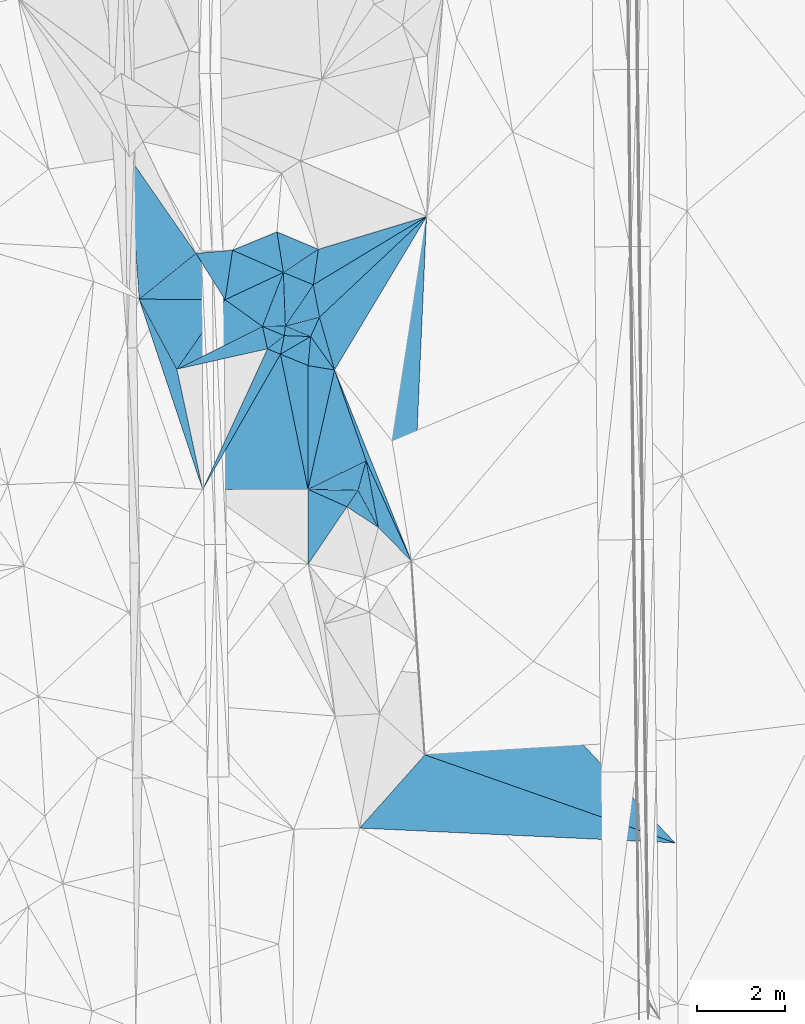
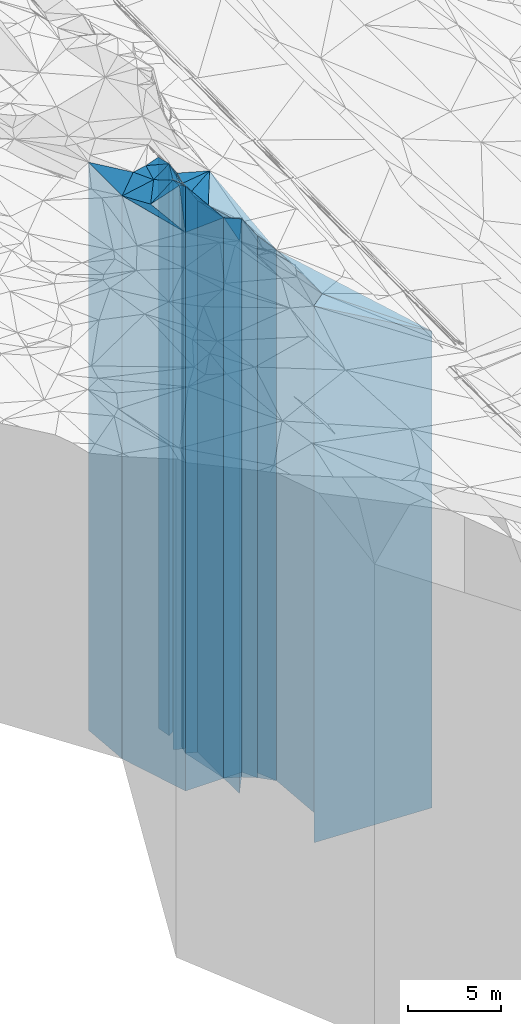
# One storey, part 197 of 275: 42 plates.
"""IFC2X3 building model written with IfcOpenShell, lengths in millimetres."""

import ifcopenshell
import ifcopenshell.guid

model = None  # the IFC model being written
_history = None  # IfcOwnerHistory: only IFC2X3 demands one
_inside = {}  # id of a spatial element -> (the spatial element, [elements in it])
_under = {}  # id of a project, library or spatial element -> (it, [spatial elements below it])
_declared = {}  # id of a project -> (the project, [libraries it declares])
_typed = {}  # id of a type object -> (the type object, [elements of that type])
_made_of = {}  # id of a material, layer set ... -> (it, [elements and type objects made of it])


def new_model(schema):
    """Start an empty IFC model of exactly this schema.

    Asked for "IFC4X3", IfcOpenShell would pick the latest addendum, in which some entities
    have other attributes; the version numbers below select the first issue.
    IFC2X3 requires an IfcOwnerHistory on every rooted entity: one is made here for all.
    """
    global model, _history
    if schema == "IFC4X3":
        model = ifcopenshell.file(schema_version=(4, 3, 0, 0))
    else:
        model = ifcopenshell.file(schema=schema)
    _inside.clear()
    _under.clear()
    _declared.clear()
    _typed.clear()
    _made_of.clear()
    _history = None
    if model.schema == "IFC2X3":
        org = make("IfcOrganization", Name="unknown")
        user = make(
            "IfcPersonAndOrganization",
            ThePerson=make("IfcPerson", FamilyName="unknown"),
            TheOrganization=org,
        )
        app = make(
            "IfcApplication",
            ApplicationDeveloper=org,
            Version="unknown",
            ApplicationFullName="unknown",
            ApplicationIdentifier="unknown",
        )
        _history = make(
            "IfcOwnerHistory",
            OwningUser=user,
            OwningApplication=app,
            ChangeAction="ADDED",
            CreationDate=0,
        )
    return model


def make(cls, **values):
    """One entity of the class cls with the attributes given. An attribute that is None is left unset."""
    return model.create_entity(
        cls, **{name: value for name, value in values.items() if value is not None}
    )


def rooted(cls, **values):
    """An entity with a GlobalId (a new one), such as an element, a storey or a relation."""
    return make(cls, GlobalId=ifcopenshell.guid.new(), OwnerHistory=_history, **values)


def si_unit(unit_type, name, prefix=None):
    """IfcSIUnit, for example si_unit("LENGTHUNIT", "METRE", prefix="MILLI")."""
    return make("IfcSIUnit", UnitType=unit_type, Prefix=prefix, Name=name)


def assignment(units):
    """IfcUnitAssignment: the units of a project."""
    return None if units is None else make("IfcUnitAssignment", Units=units)


def point(xyz):
    """IfcCartesianPoint."""
    return None if xyz is None else make("IfcCartesianPoint", Coordinates=xyz)


def direction(xyz):
    """IfcDirection."""
    return None if xyz is None else make("IfcDirection", DirectionRatios=xyz)


def frame(location, z_axis=None, x_axis=None):
    """IfcAxis2Placement3D, a coordinate frame: its origin and axes. An axis left out is left unset."""
    return make(
        "IfcAxis2Placement3D",
        Location=point(location),
        Axis=direction(z_axis),
        RefDirection=direction(x_axis),
    )


def origin_with_axes():
    """The frame at (0, 0, 0) with the z axis (0, 0, 1) and the x axis (1, 0, 0) written out."""
    return frame((0.0, 0.0, 0.0), z_axis=(0.0, 0.0, 1.0), x_axis=(1.0, 0.0, 0.0))


def place(relative_to, where):
    """IfcLocalPlacement: puts the frame where relative to a parent placement (None: the world)."""
    return make(
        "IfcLocalPlacement", PlacementRelTo=relative_to, RelativePlacement=where
    )


def context(
    kind, dimensions, precision=None, world=None, true_north=None, identifier=None
):
    """IfcGeometricRepresentationContext, for example the 3D "Model" context."""
    return make(
        "IfcGeometricRepresentationContext",
        ContextIdentifier=identifier,
        ContextType=kind,
        CoordinateSpaceDimension=dimensions,
        Precision=precision,
        WorldCoordinateSystem=world,
        TrueNorth=true_north,
    )


def subcontext(parent, identifier, kind, view, scale=None):
    """IfcGeometricRepresentationSubContext, for example "Body" below "Model"."""
    return make(
        "IfcGeometricRepresentationSubContext",
        ContextIdentifier=identifier,
        ContextType=kind,
        ParentContext=parent,
        TargetScale=scale,
        TargetView=view,
    )


def project(units=None, contexts=None):
    """IfcProject with its units and contexts."""
    return rooted(
        "IfcProject",
        Name="project",
        RepresentationContexts=contexts,
        UnitsInContext=assignment(units),
    )


def spatial(cls, under=None, at=None, **own):
    """A site, building, storey or space (cls), placed at a placement, below another one or the project."""
    s = rooted(cls, ObjectPlacement=at, **own)
    if under is not None:
        _under.setdefault(under.id(), (under, []))[1].append(s)
    return s


def faces_of(points, faces, orient=None, outer=None):
    """IfcFace entities. A face is a list of loops; a loop is a list of indices into points, from 0.

    orient and outer hold one flag for each loop. By default every Orientation is true, the
    first loop of a face is its IfcFaceOuterBound and the others are IfcFaceBound.
    """
    made = []
    for i, loops in enumerate(faces):
        bounds = []
        for j, loop in enumerate(loops):
            is_outer = j == 0 if outer is None else outer[i][j]
            bounds.append(
                make(
                    "IfcFaceOuterBound" if is_outer else "IfcFaceBound",
                    Bound=make("IfcPolyLoop", Polygon=[points[k] for k in loop]),
                    Orientation=True if orient is None else orient[i][j],
                )
            )
        made.append(make("IfcFace", Bounds=bounds))
    return made


def faceted_brep(points, faces, orient=None, outer=None, voids=None):
    """IfcFacetedBrep: a solid bounded by flat faces; with voids (closed shells), ...WithVoids."""
    shared = [point(p) for p in points]
    hull = make("IfcClosedShell", CfsFaces=faces_of(shared, faces, orient, outer))
    if voids is None:
        return make("IfcFacetedBrep", Outer=hull)
    return make(
        "IfcFacetedBrepWithVoids",
        Outer=hull,
        Voids=[
            make(cls, CfsFaces=faces_of(shared, fs, o, b)) for cls, fs, o, b in voids
        ],
    )


def shape(context_of_items, identifier, shape_type, items):
    """IfcShapeRepresentation: the items that make up one representation, for example the "Body"."""
    return make(
        "IfcShapeRepresentation",
        ContextOfItems=context_of_items,
        RepresentationIdentifier=identifier,
        RepresentationType=shape_type,
        Items=items,
    )


def material(Name=None, Category=None):
    """IfcMaterial."""
    return make("IfcMaterial", Name=Name, Category=Category)


def made_of(thing, what):
    """Note that an element or type object is made of a material, layer set ...; save() writes the relation."""
    if what is not None:
        _made_of.setdefault(what.id(), (what, []))[1].append(thing)
    return thing


def type_object(cls, material=None, **own):
    """A type object (cls), such as IfcWallType, which elements share."""
    return made_of(rooted(cls, **own), material)


def element(
    cls,
    number,
    at=None,
    inside=None,
    cuts=None,
    type_object=None,
    material=None,
    context=None,
    identifier="Body",
    shape_type=None,
    held_by="IfcProductDefinitionShape",
    body=None,
    shapes=None,
    **own,
):
    """One element of the class cls, such as IfcWall. Its Tag is "e" and its number.

    at: its placement. inside: the storey or other place that contains it. cuts: it is an
    opening in that element (IfcRelVoidsElement). A single representation is given by context,
    identifier, shape_type and body (its items); several are given by shapes. held_by: the class
    of the entity that holds the representations. save() writes the other relations.
    """
    e = rooted(cls, Tag="e%d" % number, ObjectPlacement=at, **own)
    if body is not None:
        shapes = [shape(context, identifier, shape_type, body)]
    if shapes is not None:
        e.Representation = make(held_by, Representations=shapes)
    if inside is not None:
        _inside.setdefault(inside.id(), (inside, []))[1].append(e)
    if cuts is not None:
        rooted(
            "IfcRelVoidsElement", RelatingBuildingElement=cuts, RelatedOpeningElement=e
        )
    if type_object is not None:
        _typed.setdefault(type_object.id(), (type_object, []))[1].append(e)
    return made_of(e, material)


def aggregate(whole, parts):
    """IfcRelAggregates: a whole, such as a stair, and the parts it consists of."""
    return rooted("IfcRelAggregates", RelatingObject=whole, RelatedObjects=parts)


def save(model, path):
    """Write the relations noted so far, then the file.

    IfcRelAggregates (storeys below a building ...), IfcRelContainedInSpatialStructure (elements
    in a storey), IfcRelDefinesByType, IfcRelAssociatesMaterial and IfcRelDeclares: one each for
    every whole, place, type object, material and project.
    """
    for whole, parts in _under.values():
        aggregate(whole, parts)
    for where, things in _inside.values():
        rooted(
            "IfcRelContainedInSpatialStructure",
            RelatedElements=things,
            RelatingStructure=where,
        )
    for kind, things in _typed.values():
        rooted("IfcRelDefinesByType", RelatedObjects=things, RelatingType=kind)
    for what, things in _made_of.values():
        rooted("IfcRelAssociatesMaterial", RelatedObjects=things, RelatingMaterial=what)
    for by, libraries in _declared.values():
        rooted("IfcRelDeclares", RelatingContext=by, RelatedDefinitions=libraries)
    model.write(path)


model = new_model("IFC2X3")

# Units and contexts
model_context = context("Model", 3, precision=1e-05, world=origin_with_axes())
body_context = subcontext(model_context, "Body", "Model", "MODEL_VIEW")
ifc_project = project(units=[si_unit("LENGTHUNIT", "METRE", prefix="MILLI"), si_unit("AREAUNIT", "SQUARE_METRE"), si_unit("VOLUMEUNIT", "CUBIC_METRE"), si_unit("MASSUNIT", "GRAM", prefix="KILO"), si_unit("TIMEUNIT", "SECOND"), si_unit("PLANEANGLEUNIT", "RADIAN"), si_unit("SOLIDANGLEUNIT", "STERADIAN"), si_unit("THERMODYNAMICTEMPERATUREUNIT", "DEGREE_CELSIUS"), si_unit("LUMINOUSINTENSITYUNIT", "LUMEN")], contexts=[model_context])

# Site, building, storey
site_placement = place(None, origin_with_axes())
site = spatial("IfcSite", under=ifc_project, at=site_placement, CompositionType="ELEMENT")
building_placement = place(site_placement, origin_with_axes())
building = spatial("IfcBuilding", under=site, at=building_placement, Name="Undefined", CompositionType="ELEMENT")
storey_placement = place(building_placement, origin_with_axes())
storey = spatial("IfcBuildingStorey", under=building, at=storey_placement, Name="Undefined", CompositionType="ELEMENT", Elevation=0.0)

# Plates
ifc_material = material()
plate_type_1 = type_object("IfcPlateType", PredefinedType="NOTDEFINED")
plate_1_placement = place(storey_placement, frame((-98977.5774845146, 11704.5980835272, 23535.0), z_axis=(0.997621794008999, 0.0689257290006218, 0.0), x_axis=(0.0689257290006226, -0.997621794008999, 0.0)))
element("IfcPlate", 1, at=plate_1_placement, inside=storey, type_object=plate_type_1, material=ifc_material, Name="00", context=body_context, shape_type="Brep", body=[
    faceted_brep([(0.0, -19252.4609375, 0.0), (6798.1015625, -15707.0, 5531.57373046875), (6798.1015625, 15707.0, 5531.57373046875), (0.0, 15707.0, 0.0), (4412.50537109375, -18941.4609375, 3.08500602841377e-09), (4412.50537109375, 15707.0, 3.08500602841377e-09)], [[[0, 1, 2, 3]], [[1, 4, 5, 2]], [[4, 0, 3, 5]], [[5, 3, 2]], [[4, 1, 0]]]),
])
plate_type_2 = type_object("IfcPlateType", PredefinedType="NOTDEFINED")
plate_2_placement = place(storey_placement, frame((-102030.296716859, 19177.3864713029, 26639.0), z_axis=(0.37908068696638, -0.925363621917945, 0.0), x_axis=(-0.925363621917943, -0.379080686966386, 0.0)))
element("IfcPlate", 2, at=plate_2_placement, inside=storey, type_object=plate_type_2, material=ifc_material, Name="00", context=body_context, shape_type="Brep", body=[
    faceted_brep([(0.0, -18811.0, 0.0), (215.147888183594, -18881.0, 906.262329101548), (215.147888183594, 18811.0, 906.262329101548), (0.0, 18811.0, 0.0), (1090.41271972656, -18861.0, -5.0931703299284e-10), (1090.41271972656, 18811.0, -5.0931703299284e-10)], [[[0, 1, 2, 3]], [[1, 4, 5, 2]], [[4, 0, 3, 5]], [[5, 3, 2]], [[4, 1, 0]]]),
])
plate_type_3 = type_object("IfcPlateType", PredefinedType="NOTDEFINED")
plate_3_placement = place(storey_placement, frame((-101205.072402421, 17978.7185311039, 25489.0), z_axis=(-0.516023395156627, 0.856574489259998, 0.0), x_axis=(0.856574489259998, 0.516023395156628, 0.0)))
element("IfcPlate", 3, at=plate_3_placement, inside=storey, type_object=plate_type_3, material=ifc_material, Name="00", context=body_context, shape_type="Brep", body=[
    faceted_brep([(0.0, -18681.0, 0.0), (513.227783203125, -18821.0, 630.553161621094), (513.227783203125, 17661.0, 630.553161621094), (-2.91038304567337e-11, 17661.0, 1.45519152283669e-11), (3002.76049804688, -17661.0, 1.71858118847013e-08), (3002.76049804688, 17661.0, 1.71858118847013e-08)], [[[0, 1, 2, 3]], [[1, 4, 5, 2]], [[4, 0, 3, 5]], [[5, 3, 2]], [[4, 1, 0]]]),
])
plate_type_4 = type_object("IfcPlateType", PredefinedType="NOTDEFINED")
plate_4_placement = place(storey_placement, frame((-101090.834766413, 18783.6717983929, 25999.0), z_axis=(0.552128983358343, -0.833758709541125, 0.0), x_axis=(-0.833758709541124, -0.552128983358345, 0.0)))
element("IfcPlate", 4, at=plate_4_placement, inside=storey, type_object=plate_type_4, material=ifc_material, Name="00", context=body_context, shape_type="Brep", body=[
    faceted_brep([(-1.45519152283669e-11, -18311.0, 1.45519152283669e-11), (539.684631347642, -18171.0, 608.062866210952), (539.684631347642, 18171.0, 608.062866210952), (-1.45519152283669e-11, 18171.0, 1.45519152283669e-11), (953.51977539061, -19521.0, -6.98491930961609e-10), (953.51977539061, 18171.0, -6.98491930961609e-10)], [[[0, 1, 2, 3]], [[1, 4, 5, 2]], [[4, 0, 3, 5]], [[5, 3, 2]], [[4, 1, 0]]]),
])
plate_type_5 = type_object("IfcPlateType", PredefinedType="NOTDEFINED")
plate_5_placement = place(storey_placement, frame((-101840.435153924, 17041.7477876956, 25939.0), z_axis=(-0.250525793019812, 0.968109925076587, 0.0), x_axis=(0.968109925076585, 0.250525793019819, 0.0)))
element("IfcPlate", 5, at=plate_5_placement, inside=storey, type_object=plate_type_5, material=ifc_material, Name="00", context=body_context, shape_type="Brep", body=[
    faceted_brep([(-1.45519152283669e-11, -18941.0, 0.0), (849.836303710923, -18231.0, 747.915893554688), (849.836303710923, 18111.0, 747.915893554688), (-1.45519152283669e-11, 18111.0, 0.0), (800.624755859375, -18111.0, 4.35829861089587e-09), (800.624755859375, 18111.0, 4.35829861089587e-09)], [[[0, 1, 2, 3]], [[1, 4, 5, 2]], [[4, 0, 3, 5]], [[5, 3, 2]], [[4, 1, 0]]]),
])
plate_type_6 = type_object("IfcPlateType", PredefinedType="NOTDEFINED")
plate_6_placement = place(storey_placement, frame((-101885.840200398, 18257.205883129, 26069.0), z_axis=(-0.552128983358343, 0.833758709541125, 0.0), x_axis=(0.833758709541123, 0.552128983358347, 0.0)))
element("IfcPlate", 6, at=plate_6_placement, inside=storey, type_object=plate_type_6, material=ifc_material, Name="00", context=body_context, shape_type="Brep", body=[
    faceted_brep([(0.0, -19451.0, 0.0), (387.616485595689, -19381.0, 846.967224121094), (387.616485595689, 18241.0, 846.967224121094), (0.0, 18241.0, 0.0), (953.519775390625, -18241.0, -6.98491930961609e-10), (953.519775390625, 18241.0, -6.98491930961609e-10)], [[[0, 1, 2, 3]], [[1, 4, 5, 2]], [[4, 0, 3, 5]], [[5, 3, 2]], [[4, 1, 0]]]),
])
plate_type_7 = type_object("IfcPlateType", PredefinedType="NOTDEFINED")
plate_7_placement = place(storey_placement, frame((-101205.072402421, 17978.7185311039, 25999.0), z_axis=(-0.378622870041879, -0.925551037102358, 0.0), x_axis=(-0.925551037102361, 0.378622870041871, 0.0)))
element("IfcPlate", 7, at=plate_7_placement, inside=storey, type_object=plate_type_7, material=ifc_material, Name="00", context=body_context, shape_type="Brep", body=[
    faceted_brep([(-1.45519152283669e-11, -18171.0, 7.27595761418343e-12), (233.302108764634, -18881.0, 1107.77709960938), (233.302108764634, 18171.0, 1107.77709960938), (-1.45519152283669e-11, 18171.0, 1.45519152283669e-11), (735.527038574204, -19521.0, -3.1177478376776e-09), (735.527038574204, 18171.0, -3.1177478376776e-09)], [[[0, 1, 2, 3]], [[1, 4, 5, 2]], [[4, 0, 3, 5]], [[5, 3, 2]], [[4, 1, 0]]]),
])
plate_type_8 = type_object("IfcPlateType", PredefinedType="NOTDEFINED")
plate_8_placement = place(storey_placement, frame((-102360.3146659, 17030.5543508726, 26354.0), z_axis=(-0.0215258400056386, 0.999768292261788, 0.0), x_axis=(0.999768292261788, 0.0215258400056351, 0.0)))
element("IfcPlate", 8, at=plate_8_placement, inside=storey, type_object=plate_type_8, material=ifc_material, Name="00", context=body_context, shape_type="Brep", body=[
    faceted_brep([(-1.45519152283669e-11, -19006.0, 3.63797880709171e-12), (500.769226074204, -19166.0, 1216.15380859375), (500.769226074204, 18526.0, 1216.15380859375), (-1.45519152283669e-11, 18526.0, 3.63797880709171e-12), (519.999999999985, -18526.0, 3.04135028272867e-09), (519.999999999985, 18526.0, 3.04135028272867e-09)], [[[0, 1, 2, 3]], [[1, 4, 5, 2]], [[4, 0, 3, 5]], [[5, 3, 2]], [[4, 1, 0]]]),
])
plate_type_9 = type_object("IfcPlateType", PredefinedType="NOTDEFINED")
plate_9_placement = place(storey_placement, frame((-101205.072402421, 17978.7185311039, 25489.0), z_axis=(0.982469626415243, 0.186422727078792, 0.0), x_axis=(0.186422727078798, -0.982469626415241, 0.0)))
element("IfcPlate", 9, at=plate_9_placement, inside=storey, type_object=plate_type_9, material=ifc_material, Name="00", context=body_context, shape_type="Brep", body=[
    faceted_brep([(0.0, -18681.0, 0.0), (-1042.8356933594, -17661.0, 2815.859375), (-1042.8356933594, 17661.0, 2815.859375), (-2.91038304567337e-11, 17661.0, 1.45519152283669e-11), (749.533203124993, -18561.0, 1.25146470963955e-09), (749.533203124993, 17661.0, 1.25146470963955e-09)], [[[0, 1, 2, 3]], [[1, 4, 5, 2]], [[4, 0, 3, 5]], [[5, 3, 2]], [[4, 1, 0]]]),
])
plate_type_10 = type_object("IfcPlateType", PredefinedType="NOTDEFINED")
plate_10_placement = place(storey_placement, frame((-103209.000762078, 17639.3498092609, 26569.0), z_axis=(0.582879703926358, 0.812558459897331, 0.0), x_axis=(0.812558459897334, -0.582879703926353, 0.0)))
element("IfcPlate", 10, at=plate_10_placement, inside=storey, type_object=plate_type_10, material=ifc_material, Name="00", context=body_context, shape_type="Brep", body=[
    faceted_brep([(0.0, -18741.0, -1.45519152283669e-11), (715.009521484375, -18951.0, 1273.28759765624), (715.009521484375, 18741.0, 1273.28759765624), (0.0, 18741.0, -1.45519152283669e-11), (1044.46154785156, -18791.0, -5.81349013373256e-09), (1044.46154785156, 18741.0, -5.81349013373256e-09)], [[[0, 1, 2, 3]], [[1, 4, 5, 2]], [[4, 0, 3, 5]], [[5, 3, 2]], [[4, 1, 0]]]),
])
plate_type_11 = type_object("IfcPlateType", PredefinedType="NOTDEFINED")
plate_11_placement = place(storey_placement, frame((-101065.342381393, 17242.3249398611, 25939.0), z_axis=(0.250525793019812, -0.968109925076587, 0.0), x_axis=(-0.968109925076585, -0.250525793019819, 0.0)))
element("IfcPlate", 11, at=plate_11_placement, inside=storey, type_object=plate_type_11, material=ifc_material, Name="00", context=body_context, shape_type="Brep", body=[
    faceted_brep([(0.0, -18111.0, 0.0), (303.263153076157, -18181.0, 374.207763671875), (303.263153076157, 18111.0, 374.207763671875), (-1.45519152283669e-11, 18111.0, 0.0), (800.624755859375, -18941.0, 4.36557456851006e-09), (800.624755859375, 18111.0, 4.35829861089587e-09)], [[[0, 1, 2, 3]], [[1, 4, 5, 2]], [[4, 0, 3, 5]], [[5, 3, 2]], [[4, 1, 0]]]),
])
plate_type_12 = type_object("IfcPlateType", PredefinedType="NOTDEFINED")
plate_12_placement = place(storey_placement, frame((-104304.522036039, 16061.5560526824, 26434.0), z_axis=(-0.446069600734748, 0.894998274467802, 0.0), x_axis=(0.894998274467801, 0.44606960073475, 0.0)))
element("IfcPlate", 12, at=plate_12_placement, inside=storey, type_object=plate_type_12, material=ifc_material, Name="00", context=body_context, shape_type="Brep", body=[
    faceted_brep([(1.45519152283669e-11, -18606.0, -7.27595761418343e-12), (1684.29553222656, -18876.0, 923.443969726555), (1684.29553222656, 18606.0, 923.443969726555), (1.45519152283669e-11, 18606.0, -7.27595761418343e-12), (2172.30297851563, -18926.0, 7.49423634260893e-09), (2172.30297851563, 18606.0, 7.49423634260893e-09)], [[[0, 1, 2, 3]], [[1, 4, 5, 2]], [[4, 0, 3, 5]], [[5, 3, 2]], [[4, 1, 0]]]),
])
plate_type_13 = type_object("IfcPlateType", PredefinedType="NOTDEFINED")
plate_13_placement = place(storey_placement, frame((-105161.285860759, 17653.0207078513, 26372.5), z_axis=(0.00700234000222417, 0.999975483316713, 0.0), x_axis=(0.999975483316713, -0.00700234000221785, 0.0)))
element("IfcPlate", 13, at=plate_13_placement, inside=storey, type_object=plate_type_13, material=ifc_material, Name="00", context=body_context, shape_type="Brep", body=[
    faceted_brep([(-1.45519152283669e-11, -18544.5, 0.0), (1282.94921874999, -19027.5, 1047.48522949219), (1282.94921874999, 18544.5, 1047.48522949219), (-1.45519152283669e-11, 18544.5, 0.0), (1952.33300781247, -18937.5, -1.17688614409417e-08), (1952.33300781247, 18544.5, -1.17688614409417e-08)], [[[0, 1, 2, 3]], [[1, 4, 5, 2]], [[4, 0, 3, 5]], [[5, 3, 2]], [[4, 1, 0]]]),
])
plate_type_14 = type_object("IfcPlateType", PredefinedType="NOTDEFINED")
plate_14_placement = place(storey_placement, frame((-101864.204087832, 16823.4932624714, 25974.0), z_axis=(0.0323990509981042, 0.999475012941505, 0.0), x_axis=(0.999475012941505, -0.0323990509981041, 0.0)))
element("IfcPlate", 14, at=plate_14_placement, inside=storey, type_object=plate_type_14, material=ifc_material, Name="00", context=body_context, shape_type="Brep", body=[
    faceted_brep([(-1.45519152283669e-11, -19066.0, 0.0), (16.685216903672, -18906.0, 218.910034179686), (16.685216903672, 18146.0, 218.910034179686), (-1.45519152283669e-11, 18146.0, 0.0), (599.332946777329, -18146.0, -7.1122485678643e-10), (599.332946777329, 18146.0, -7.1122485678643e-10)], [[[0, 1, 2, 3]], [[1, 4, 5, 2]], [[4, 0, 3, 5]], [[5, 3, 2]], [[4, 1, 0]]]),
])
plate_type_15 = type_object("IfcPlateType", PredefinedType="NOTDEFINED")
plate_15_placement = place(storey_placement, frame((-100722.817014246, 16042.3431179736, 25489.0), z_axis=(-0.857676258769499, 0.514190076861811, 0.0), x_axis=(0.51419007686181, 0.8576762587695, 0.0)))
element("IfcPlate", 15, at=plate_15_placement, inside=storey, type_object=plate_type_15, material=ifc_material, Name="00", context=body_context, shape_type="Brep", body=[
    faceted_brep([(0.0, -18213.0, 0.0), (853.07275390625, -18561.0, 910.794616699219), (853.07275390625, 17661.0, 910.794616699219), (-2.91038304567337e-11, 17661.0, 1.45519152283669e-11), (4064.31909179688, -17661.0, -1.13795977085829e-08), (4064.31909179688, 17661.0, -1.13795977085829e-08)], [[[0, 1, 2, 3]], [[1, 4, 5, 2]], [[4, 0, 3, 5]], [[5, 3, 2]], [[4, 1, 0]]]),
])
plate_type_16 = type_object("IfcPlateType", PredefinedType="NOTDEFINED")
plate_16_placement = place(storey_placement, frame((-101840.435153924, 17041.7477876956, 26354.0), z_axis=(0.0215258400056386, -0.999768292261788, 0.0), x_axis=(-0.999768292261788, -0.0215258400056351, 0.0)))
element("IfcPlate", 16, at=plate_16_placement, inside=storey, type_object=plate_type_16, material=ifc_material, Name="00", context=body_context, shape_type="Brep", body=[
    faceted_brep([(1.45519152283669e-11, -18526.0, 0.0), (28.4615383148193, -18686.0, 217.692306518555), (28.4615383148193, 18526.0, 217.692306518555), (-1.45519152283669e-11, 18526.0, 3.63797880709171e-12), (520.000000000015, -19006.0, 3.03771230392158e-09), (519.999999999985, 18526.0, 3.04135028272867e-09)], [[[0, 1, 2, 3]], [[1, 4, 5, 2]], [[4, 0, 3, 5]], [[5, 3, 2]], [[4, 1, 0]]]),
])
plate_type_17 = type_object("IfcPlateType", PredefinedType="NOTDEFINED")
plate_17_placement = place(storey_placement, frame((-101323.302767628, 16144.2099918098, 25765.0), z_axis=(0.167251275010265, 0.985914302060499, 0.0), x_axis=(0.985914302060499, -0.167251275010262, 0.0)))
element("IfcPlate", 17, at=plate_17_placement, inside=storey, type_object=plate_type_17, material=ifc_material, Name="00", context=body_context, shape_type="Brep", body=[
    faceted_brep([(0.0, -18405.0, 2.72848410531878e-12), (-53.0649566650391, -18355.0, 660.290954589845), (-53.0649566650391, 17937.0, 660.290954589845), (0.0, 17937.0, 2.72848410531878e-12), (609.064880371079, -17937.0, 3.96994437323883e-09), (609.064880371079, 17937.0, 3.96994437323883e-09)], [[[0, 1, 2, 3]], [[1, 4, 5, 2]], [[4, 0, 3, 5]], [[5, 3, 2]], [[4, 1, 0]]]),
])
plate_type_18 = type_object("IfcPlateType", PredefinedType="NOTDEFINED")
plate_18_placement = place(storey_placement, frame((-101951.311359916, 16402.2898399424, 25974.0), z_axis=(0.380105042995066, 0.924943325987987, 0.0), x_axis=(0.924943325987988, -0.380105042995063, 0.0)))
element("IfcPlate", 18, at=plate_18_placement, inside=storey, type_object=plate_type_18, material=ifc_material, Name="00", context=body_context, shape_type="Brep", body=[
    faceted_brep([(-1.45519152283669e-11, -19236.0, 0.0), (481.906555175767, -18146.0, 632.428710937493), (481.906555175767, 18146.0, 632.428710937493), (-1.45519152283669e-11, 18146.0, 0.0), (678.969787597642, -18196.0, -8.00355337560177e-10), (678.969787597642, 18146.0, -8.00355337560177e-10)], [[[0, 1, 2, 3]], [[1, 4, 5, 2]], [[4, 0, 3, 5]], [[5, 3, 2]], [[4, 1, 0]]]),
])
plate_type_19 = type_object("IfcPlateType", PredefinedType="NOTDEFINED")
plate_19_placement = place(storey_placement, frame((-101065.342381393, 17242.3249398611, 25765.0), z_axis=(0.909865993098482, -0.414902247044907, 0.0), x_axis=(-0.414902247044917, -0.909865993098478, 0.0)))
element("IfcPlate", 19, at=plate_19_placement, inside=storey, type_object=plate_type_19, material=ifc_material, Name="00", context=body_context, shape_type="Brep", body=[
    faceted_brep([(7.27595761418343e-12, -18285.0, -1.45519152283669e-11), (949.708129882827, -17937.0, 809.52734375), (949.708129882827, 17937.0, 809.52734375), (0.0, 17937.0, 2.72848410531878e-12), (481.663787841801, -18355.0, -1.58615875989199e-09), (481.663787841801, 17937.0, -1.58615875989199e-09)], [[[0, 1, 2, 3]], [[1, 4, 5, 2]], [[4, 0, 3, 5]], [[5, 3, 2]], [[4, 1, 0]]]),
])
plate_type_20 = type_object("IfcPlateType", PredefinedType="NOTDEFINED")
plate_20_placement = place(storey_placement, frame((-101885.840200398, 18257.205883129, 26569.0), z_axis=(-0.402268328914255, -0.915521813804856, 0.0), x_axis=(-0.915521813804854, 0.402268328914258, 0.0)))
element("IfcPlate", 20, at=plate_20_placement, inside=storey, type_object=plate_type_20, material=ifc_material, Name="00", context=body_context, shape_type="Brep", body=[
    faceted_brep([(1.45519152283669e-11, -18951.0, 3.63797880709171e-12), (962.838439941421, -18741.0, 1097.92626953125), (962.838439941421, 18741.0, 1097.92626953125), (0.0, 18741.0, -1.45519152283669e-11), (1259.92065429688, -18931.0, -1.11685949377716e-09), (1259.92065429688, 18741.0, -1.11685949377716e-09)], [[[0, 1, 2, 3]], [[1, 4, 5, 2]], [[4, 0, 3, 5]], [[5, 3, 2]], [[4, 1, 0]]]),
])
plate_type_21 = type_object("IfcPlateType", PredefinedType="NOTDEFINED")
plate_21_placement = place(storey_placement, frame((-103039.325023073, 18764.0320504265, 26569.0), z_axis=(0.0868827749992972, -0.996218541991877, 0.0), x_axis=(-0.996218541991878, -0.0868827749992902, 0.0)))
element("IfcPlate", 21, at=plate_21_placement, inside=storey, type_object=plate_type_21, material=ifc_material, Name="00", context=body_context, shape_type="Brep", body=[
    faceted_brep([(0.0, -18931.0, 0.0), (266.749633789077, -18741.0, 1105.68737792969), (266.749633789077, 18741.0, 1105.68737792969), (0.0, 18741.0, -1.45519152283669e-11), (834.865234375015, -18831.0, -5.50789991393685e-09), (834.865234375015, 18741.0, -5.50789991393685e-09)], [[[0, 1, 2, 3]], [[1, 4, 5, 2]], [[4, 0, 3, 5]], [[5, 3, 2]], [[4, 1, 0]]]),
])
plate_type_22 = type_object("IfcPlateType", PredefinedType="NOTDEFINED")
plate_22_placement = place(storey_placement, frame((-103717.683263969, 13327.3239382497, 26228.0), z_axis=(-0.867117462759237, 0.498103709861695, 0.0), x_axis=(0.498103709861696, 0.867117462759236, 0.0)))
element("IfcPlate", 22, at=plate_22_placement, inside=storey, type_object=plate_type_22, material=ifc_material, Name="00", context=body_context, shape_type="Brep", body=[
    faceted_brep([(0.0, -18400.0, 0.0), (3504.89794921874, -19042.0, 315.586303710938), (3504.89794921874, 18400.0, 315.586303710938), (0.0, 18400.0, 0.0), (3546.19311523438, -18982.0, 8.87666828930378e-09), (3546.19311523438, 18400.0, 8.87666828930378e-09)], [[[0, 1, 2, 3]], [[1, 4, 5, 2]], [[4, 0, 3, 5]], [[5, 3, 2]], [[4, 1, 0]]]),
])
plate_type_23 = type_object("IfcPlateType", PredefinedType="NOTDEFINED")
plate_23_placement = place(storey_placement, frame((-104304.522036039, 16061.5560526824, 26434.0), z_axis=(-0.218992509967534, 0.975726539855363, 0.0), x_axis=(0.975726539855362, 0.218992509967537, 0.0)))
element("IfcPlate", 23, at=plate_23_placement, inside=storey, type_object=plate_type_23, material=ifc_material, Name="00", context=body_context, shape_type="Brep", body=[
    faceted_brep([(1.45519152283669e-11, -18606.0, -7.27595761418343e-12), (2109.21801757811, -18926.0, 519.710510253906), (2109.21801757811, 18606.0, 519.710510253906), (1.45519152283669e-11, 18606.0, -7.27595761418343e-12), (2110.21337890624, -18836.0, 1.43409124575555e-08), (2110.21337890624, 18606.0, 1.43409124575555e-08)], [[[0, 1, 2, 3]], [[1, 4, 5, 2]], [[4, 0, 3, 5]], [[5, 3, 2]], [[4, 1, 0]]]),
])
plate_type_24 = type_object("IfcPlateType", PredefinedType="NOTDEFINED")
plate_24_placement = place(storey_placement, frame((-101864.204087832, 16823.4932624714, 26434.0), z_axis=(-0.385167443836916, -0.922846704609241, 0.0), x_axis=(-0.922846704609243, 0.385167443836912, 0.0)))
element("IfcPlate", 24, at=plate_24_placement, inside=storey, type_object=plate_type_24, material=ifc_material, Name="00", context=body_context, shape_type="Brep", body=[
    faceted_brep([(1.45519152283669e-11, -18606.0, -7.27595761418343e-12), (236.4267578125, -18836.0, 423.559204101566), (236.4267578125, 18606.0, 423.559204101566), (1.45519152283669e-11, 18606.0, -7.27595761418343e-12), (537.587219238281, -18926.0, -3.31419869326055e-09), (537.587219238281, 18606.0, -3.31419869326055e-09)], [[[0, 1, 2, 3]], [[1, 4, 5, 2]], [[4, 0, 3, 5]], [[5, 3, 2]], [[4, 1, 0]]]),
])
plate_type_25 = type_object("IfcPlateType", PredefinedType="NOTDEFINED")
plate_25_placement = place(storey_placement, frame((-103871.033273747, 18691.4966400278, 26372.5), z_axis=(-0.821652914022531, -0.569988148015626, 0.0), x_axis=(-0.569988148015627, 0.82165291402253, 0.0)))
element("IfcPlate", 25, at=plate_25_placement, inside=storey, type_object=plate_type_25, material=ifc_material, Name="00", context=body_context, shape_type="Brep", body=[
    faceted_brep([(0.0, -19027.5, 0.0), (-117.838096618652, -18544.5, 1652.05871582031), (-117.838096618652, 18544.5, 1652.05871582031), (-1.45519152283669e-11, 18544.5, 0.0), (2660.97314453125, -18889.5, -5.3987605497241e-09), (2660.97314453125, 18544.5, -5.3987605497241e-09)], [[[0, 1, 2, 3]], [[1, 4, 5, 2]], [[4, 0, 3, 5]], [[5, 3, 2]], [[4, 1, 0]]]),
])
plate_type_26 = type_object("IfcPlateType", PredefinedType="NOTDEFINED")
plate_26_placement = place(storey_placement, frame((-103209.000762078, 17639.3498092609, 26372.5), z_axis=(-0.00700234000222417, -0.999975483316713, 0.0), x_axis=(-0.999975483316713, 0.0070023400022179, 0.0)))
element("IfcPlate", 26, at=plate_26_placement, inside=storey, type_object=plate_type_26, material=ifc_material, Name="00", context=body_context, shape_type="Brep", body=[
    faceted_brep([(1.45519152283669e-11, -18937.5, 3.63797880709171e-12), (1084.44616699219, -18667.5, 1585.42626953125), (1084.44616699219, 18544.5, 1585.42626953125), (-1.45519152283669e-11, 18544.5, 0.0), (1952.33300781251, -18544.5, -1.17652234621346e-08), (1952.33300781247, 18544.5, -1.17688614409417e-08)], [[[0, 1, 2, 3]], [[1, 4, 5, 2]], [[4, 0, 3, 5]], [[5, 3, 2]], [[4, 1, 0]]]),
])
plate_type_27 = type_object("IfcPlateType", PredefinedType="NOTDEFINED")
plate_27_placement = place(storey_placement, frame((-101326.629958963, 13332.7176959288, 25765.0), z_axis=(-0.976059198429088, 0.217505037095618, 0.0), x_axis=(0.217505037095619, 0.976059198429088, 0.0)))
element("IfcPlate", 27, at=plate_27_placement, inside=storey, type_object=plate_type_27, material=ifc_material, Name="00", context=body_context, shape_type="Brep", body=[
    faceted_brep([(-1.81898940354586e-12, -18995.0, 2.91038304567337e-11), (2744.90649414062, -18405.0, 608.266174316435), (2744.90649414062, 17937.0, 608.266174316435), (0.0, 17937.0, 2.72848410531878e-12), (2776.08715820312, -17937.0, -3.11410985887051e-09), (2776.08715820312, 17937.0, -3.11410985887051e-09)], [[[0, 1, 2, 3]], [[1, 4, 5, 2]], [[4, 0, 3, 5]], [[5, 3, 2]], [[4, 1, 0]]]),
])
plate_type_28 = type_object("IfcPlateType", PredefinedType="NOTDEFINED")
plate_28_placement = place(storey_placement, frame((-101326.629958963, 13332.7176959288, 25999.0), z_axis=(-0.99999929975239, 0.00118342499970624, 0.0), x_axis=(0.00118342499970787, 0.99999929975239, 0.0)))
element("IfcPlate", 28, at=plate_28_placement, inside=storey, type_object=plate_type_28, material=ifc_material, Name="00", context=body_context, shape_type="Brep", body=[
    faceted_brep([(0.0, -18761.0, 0.0), (3068.83081054688, -19211.0, 628.313598632813), (3068.83081054688, 18171.0, 628.313598632813), (-1.45519152283669e-11, 18171.0, 1.45519152283669e-11), (2811.49438476563, -18171.0, 1.13504938781261e-09), (2811.49438476563, 18171.0, 1.13504938781261e-09)], [[[0, 1, 2, 3]], [[1, 4, 5, 2]], [[4, 0, 3, 5]], [[5, 3, 2]], [[4, 1, 0]]]),
])
plate_type_29 = type_object("IfcPlateType", PredefinedType="NOTDEFINED")
plate_29_placement = place(storey_placement, frame((-104304.522036039, 16061.5560526824, 26228.0), z_axis=(-0.880512363898619, -0.474023181945425, 0.0), x_axis=(-0.474023181945422, 0.880512363898621, 0.0)))
element("IfcPlate", 29, at=plate_29_placement, inside=storey, type_object=plate_type_29, material=ifc_material, Name="00", context=body_context, shape_type="Brep", body=[
    faceted_brep([(0.0, -18812.0, 0.0), (-2685.70043945313, -18400.0, 779.37060546875), (-2685.70043945313, 18400.0, 779.37060546875), (0.0, 18400.0, 0.0), (1807.43017578125, -18689.0, -2.57568899542093e-09), (1807.43017578125, 18400.0, -2.57568899542093e-09)], [[[0, 1, 2, 3]], [[1, 4, 5, 2]], [[4, 0, 3, 5]], [[5, 3, 2]], [[4, 1, 0]]]),
])
plate_type_30 = type_object("IfcPlateType", PredefinedType="NOTDEFINED")
plate_30_placement = place(storey_placement, frame((-99729.1112312007, 12464.5967858893, 25307.5), z_axis=(0.711055604032508, 0.703135782032151, 0.0), x_axis=(0.703135782032151, -0.711055604032508, 0.0)))
element("IfcPlate", 30, at=plate_30_placement, inside=storey, type_object=plate_type_30, material=ifc_material, Name="00", context=body_context, shape_type="Brep", body=[
    faceted_brep([(0.0, -18222.5, -7.27595761418343e-12), (-1274.00793457031, -18312.5, 869.772155761726), (-1274.00793457031, 17479.5, 869.772155761726), (0.0, 17479.5, -7.27595761418343e-12), (1068.83166503906, -17479.5, 2.47382558882236e-10), (1068.83166503906, 17479.5, 2.47382558882236e-10)], [[[0, 1, 2, 3]], [[1, 4, 5, 2]], [[4, 0, 3, 5]], [[5, 3, 2]], [[4, 1, 0]]]),
])
plate_type_31 = type_object("IfcPlateType", PredefinedType="NOTDEFINED")
plate_31_placement = place(storey_placement, frame((-100006.45544676, 13982.0552486144, 25307.5), z_axis=(0.911318220107726, 0.411702686048667, 0.0), x_axis=(0.411702686048667, -0.911318220107726, 0.0)))
element("IfcPlate", 31, at=plate_31_placement, inside=storey, type_object=plate_type_31, material=ifc_material, Name="00", context=body_context, shape_type="Brep", body=[
    faceted_brep([(-1.45519152283669e-11, -18312.5, -1.45519152283669e-11), (-2172.50585937501, -18394.5, 195.392700195298), (-2172.50585937501, 17479.5, 195.392700195298), (0.0, 17479.5, -7.27595761418343e-12), (2499.08007812499, -17479.5, 3.92901711165905e-10), (2499.08007812499, 17479.5, 3.92901711165905e-10)], [[[0, 1, 2, 3]], [[1, 4, 5, 2]], [[4, 0, 3, 5]], [[5, 3, 2]], [[4, 1, 0]]]),
])
plate_type_32 = type_object("IfcPlateType", PredefinedType="NOTDEFINED")
plate_32_placement = place(storey_placement, frame((-101326.629958963, 13332.7176959288, 26069.0), z_axis=(0.407879184861376, 0.913035908689696, 0.0), x_axis=(0.913035908689695, -0.407879184861378, 0.0)))
element("IfcPlate", 32, at=plate_32_placement, inside=storey, type_object=plate_type_32, material=ifc_material, Name="00", context=body_context, shape_type="Brep", body=[
    faceted_brep([(0.0, -18691.0, 0.0), (1046.49487304688, -18241.0, 442.886596679695), (1046.49487304688, 18241.0, 442.886596679695), (0.0, 18241.0, 0.0), (970.0, -18541.0, -1.36788003146648e-09), (970.0, 18241.0, -1.36788003146648e-09)], [[[0, 1, 2, 3]], [[1, 4, 5, 2]], [[4, 0, 3, 5]], [[5, 3, 2]], [[4, 1, 0]]]),
])
plate_type_33 = type_object("IfcPlateType", PredefinedType="NOTDEFINED")
plate_33_placement = place(storey_placement, frame((-100190.498362333, 13310.2455990652, 25679.0), z_axis=(0.830293936976665, -0.55732573798434, 0.0), x_axis=(-0.557325737984339, -0.830293936976666, 0.0)))
element("IfcPlate", 33, at=plate_33_placement, inside=storey, type_object=plate_type_33, material=ifc_material, Name="00", context=body_context, shape_type="Brep", body=[
    faceted_brep([(0.0, -18631.0, 0.0), (444.994171142578, -17851.0, 854.388793945298), (444.994171142578, 17851.0, 854.388793945298), (0.0, 17851.0, 0.0), (449.444091796875, -18931.0, 1.38243194669485e-09), (449.444091796875, 17851.0, 1.38243194669485e-09)], [[[0, 1, 2, 3]], [[1, 4, 5, 2]], [[4, 0, 3, 5]], [[5, 3, 2]], [[4, 1, 0]]]),
])
plate_type_34 = type_object("IfcPlateType", PredefinedType="NOTDEFINED")
plate_34_placement = place(storey_placement, frame((-101322.560329678, 11632.1035603538, 26040.5), z_axis=(-0.82863673809214, 0.559786706062245, 0.0), x_axis=(0.559786706062246, 0.828636738092139, 0.0)))
element("IfcPlate", 34, at=plate_34_placement, inside=storey, type_object=plate_type_34, material=ifc_material, Name="00", context=body_context, shape_type="Brep", body=[
    faceted_brep([(-7.27595761418343e-12, -18212.5, 0.0), (1406.91320800781, -18719.5, 955.353454589858), (1406.91320800781, 18212.5, 955.353454589858), (-7.27595761418343e-12, 18212.5, 0.0), (1574.84130859375, -18569.5, 8.44011083245277e-10), (1574.84130859375, 18212.5, 8.44011083245277e-10)], [[[0, 1, 2, 3]], [[1, 4, 5, 2]], [[4, 0, 3, 5]], [[5, 3, 2]], [[4, 1, 0]]]),
])
plate_type_35 = type_object("IfcPlateType", PredefinedType="NOTDEFINED")
plate_35_placement = place(storey_placement, frame((-100006.45544676, 13982.0552486144, 25724.0), z_axis=(-0.944533818430334, -0.328414168149628, 0.0), x_axis=(-0.328414168149628, 0.944533818430334, 0.0)))
element("IfcPlate", 35, at=plate_35_placement, inside=storey, type_object=plate_type_35, material=ifc_material, Name="00", context=body_context, shape_type="Brep", body=[
    faceted_brep([(0.0, -17896.0, 0.0), (-179.757263183594, -19036.0, 1460.201171875), (-179.757263183594, 17896.0, 1460.201171875), (0.0, 17896.0, 0.0), (2181.27490234375, -17978.0, 4.8748916015029e-09), (2181.27490234375, 17896.0, 4.8748916015029e-09)], [[[0, 1, 2, 3]], [[1, 4, 5, 2]], [[4, 0, 3, 5]], [[5, 3, 2]], [[4, 1, 0]]]),
])
plate_type_36 = type_object("IfcPlateType", PredefinedType="NOTDEFINED")
plate_36_placement = place(storey_placement, frame((-101326.629958963, 13332.7176959288, 25724.0), z_axis=(0.0197756160076055, 0.999804443384565, 0.0), x_axis=(0.999804443384565, -0.0197756160076067, 0.0)))
element("IfcPlate", 36, at=plate_36_placement, inside=storey, type_object=plate_type_36, material=ifc_material, Name="00", context=body_context, shape_type="Brep", body=[
    faceted_brep([(-1.45519152283669e-11, -19036.0, 0.0), (1307.0753173828, -17896.0, 675.317810058596), (1307.0753173828, 17896.0, 675.317810058596), (0.0, 17896.0, 0.0), (1136.35375976561, -18586.0, -4.67480276711285e-09), (1136.35375976561, 17896.0, -4.67480276711285e-09)], [[[0, 1, 2, 3]], [[1, 4, 5, 2]], [[4, 0, 3, 5]], [[5, 3, 2]], [[4, 1, 0]]]),
])
plate_type_37 = type_object("IfcPlateType", PredefinedType="NOTDEFINED")
plate_37_placement = place(storey_placement, frame((-100006.45544676, 13982.0552486144, 25679.0), z_axis=(0.964463599813498, -0.264215753948907, 0.0), x_axis=(-0.264215753948916, -0.964463599813495, 0.0)))
element("IfcPlate", 37, at=plate_37_placement, inside=storey, type_object=plate_type_37, material=ifc_material, Name="00", context=body_context, shape_type="Brep", body=[
    faceted_brep([(1.81898940354586e-12, -17941.0, -1.45519152283669e-11), (1390.2547607422, -17851.0, 668.424804687485), (1390.2547607422, 17851.0, 668.424804687485), (0.0, 17851.0, 0.0), (696.562988281255, -18631.0, -6.54836185276508e-10), (696.562988281255, 17851.0, -6.54836185276508e-10)], [[[0, 1, 2, 3]], [[1, 4, 5, 2]], [[4, 0, 3, 5]], [[5, 3, 2]], [[4, 1, 0]]]),
])
plate_type_38 = type_object("IfcPlateType", PredefinedType="NOTDEFINED")
plate_38_placement = place(storey_placement, frame((-92990.5948340277, 5303.93136843647, 23535.0), z_axis=(-0.331778380854274, -0.943357358585662, 0.0), x_axis=(-0.943357358585661, 0.331778380854277, 0.0)))
element("IfcPlate", 38, at=plate_38_placement, inside=storey, type_object=plate_type_38, material=ifc_material, Name="00", context=body_context, shape_type="Brep", body=[
    faceted_brep([(-1.45519152283669e-11, -15707.0, 1.81898940354586e-12), (6868.03955078126, -19658.4609375, 2060.17333984376), (6868.03955078126, 15707.0, 2060.17333984376), (0.0, 15707.0, 0.0), (6024.06640625, -18941.4609375, -2.99223756883293e-08), (6024.06640625, 15707.0, -2.99223756883293e-08)], [[[0, 1, 2, 3]], [[1, 4, 5, 2]], [[4, 0, 3, 5]], [[5, 3, 2]], [[4, 1, 0]]]),
])
plate_type_39 = type_object("IfcPlateType", PredefinedType="NOTDEFINED")
plate_39_placement = place(storey_placement, frame((-98632.9844491125, 19528.2131456294, 25307.5), z_axis=(0.857676258769499, -0.514190076861811, 0.0), x_axis=(-0.514190076861811, -0.857676258769499, 0.0)))
element("IfcPlate", 39, at=plate_39_placement, inside=storey, type_object=plate_type_39, material=ifc_material, Name="00", context=body_context, shape_type="Brep", body=[
    faceted_brep([(7.27595761418343e-12, -17842.5, -1.45519152283669e-11), (6887.31542968751, -17479.5, 3727.27587890624), (6887.31542968751, 17479.5, 3727.27587890624), (0.0, 17479.5, -7.27595761418343e-12), (4064.31909179688, -18394.5, -1.52358552441001e-08), (4064.31909179688, 17479.5, -1.52358552441001e-08)], [[[0, 1, 2, 3]], [[1, 4, 5, 2]], [[4, 0, 3, 5]], [[5, 3, 2]], [[4, 1, 0]]]),
])
plate_type_40 = type_object("IfcPlateType", PredefinedType="NOTDEFINED")
plate_40_placement = place(storey_placement, frame((-101265.185767324, 16804.0754434556, 25974.0), z_axis=(-0.0323990509981042, -0.999475012941505, 0.0), x_axis=(-0.999475012941505, 0.0323990509981049, 0.0)))
element("IfcPlate", 40, at=plate_40_placement, inside=storey, type_object=plate_type_40, material=ifc_material, Name="00", context=body_context, shape_type="Brep", body=[
    faceted_brep([(1.45519152283669e-11, -18146.0, 0.0), (672.747924804717, -19236.0, 423.804473876951), (672.747924804717, 18146.0, 423.804473876951), (-1.45519152283669e-11, 18146.0, 0.0), (599.332946777358, -19066.0, -7.14862835593522e-10), (599.332946777329, 18146.0, -7.1122485678643e-10)], [[[0, 1, 2, 3]], [[1, 4, 5, 2]], [[4, 0, 3, 5]], [[5, 3, 2]], [[4, 1, 0]]]),
])
plate_type_41 = type_object("IfcPlateType", PredefinedType="NOTDEFINED")
plate_41_placement = place(storey_placement, frame((-102245.530953927, 16523.676950049, 26434.0), z_axis=(0.38138872487266, 0.924414755691409, 0.0), x_axis=(0.9244147556914, -0.38138872487268, 0.0)))
element("IfcPlate", 41, at=plate_41_placement, inside=storey, type_object=plate_type_41, material=ifc_material, Name="00", context=body_context, shape_type="Brep", body=[
    faceted_brep([(2.91038304567337e-11, -18836.0, 1.09139364212751e-11), (238.157623291045, -18606.0, 422.588378906261), (238.157623291045, 18606.0, 422.588378906261), (1.45519152283669e-11, 18606.0, -7.27595761418343e-12), (318.27661132814, -18776.0, 6.43922248855233e-10), (318.27661132814, 18606.0, 6.43922248855233e-10)], [[[0, 1, 2, 3]], [[1, 4, 5, 2]], [[4, 0, 3, 5]], [[5, 3, 2]], [[4, 1, 0]]]),
])
plate_type_42 = type_object("IfcPlateType", PredefinedType="NOTDEFINED")
plate_42_placement = place(storey_placement, frame((-101951.311359916, 16402.2898399424, 26228.0), z_axis=(0.867117462759237, -0.498103709861695, 0.0), x_axis=(-0.498103709861695, -0.867117462759237, 0.0)))
element("IfcPlate", 42, at=plate_42_placement, inside=storey, type_object=plate_type_42, material=ifc_material, Name="00", context=body_context, shape_type="Brep", body=[
    faceted_brep([(0.0, -18982.0, 0.0), (2350.5234375, -18532.0, 2070.63745117189), (2350.5234375, 18400.0, 2070.63745117189), (0.0, 18400.0, 0.0), (3546.19311523438, -18400.0, 5.64614310860634e-09), (3546.19311523438, 18400.0, 8.87666828930378e-09)], [[[0, 1, 2, 3]], [[1, 4, 5, 2]], [[4, 0, 3, 5]], [[5, 3, 2]], [[4, 1, 0]]]),
])

save(model, "model.ifc")
